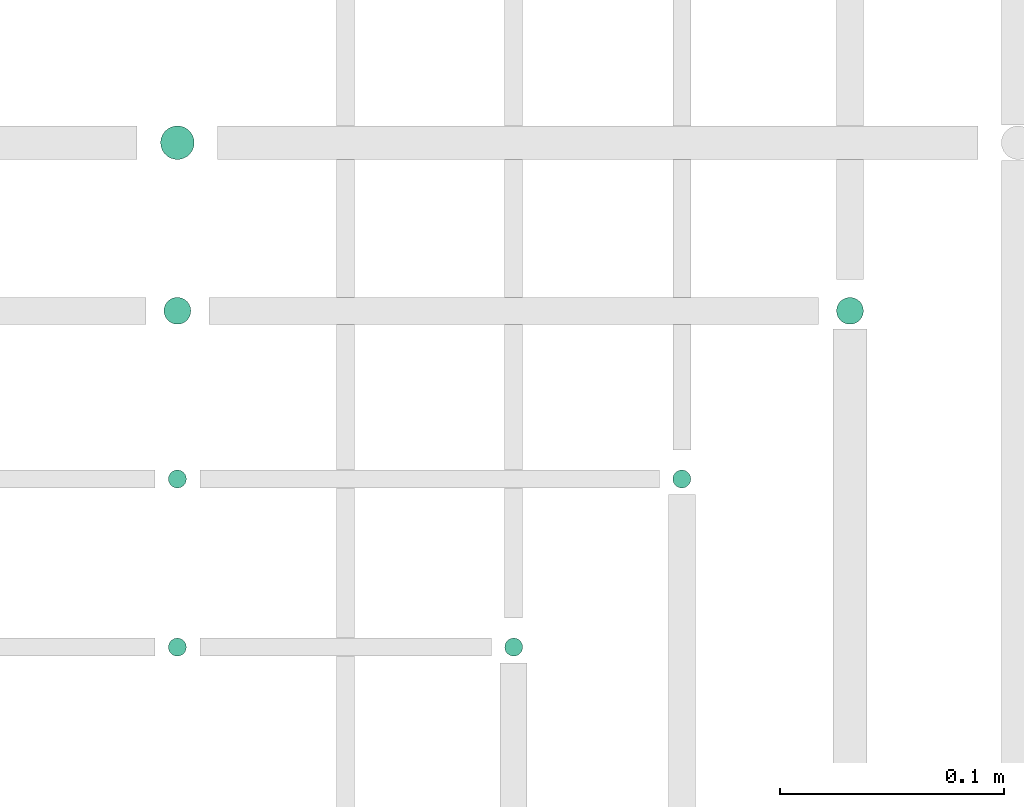
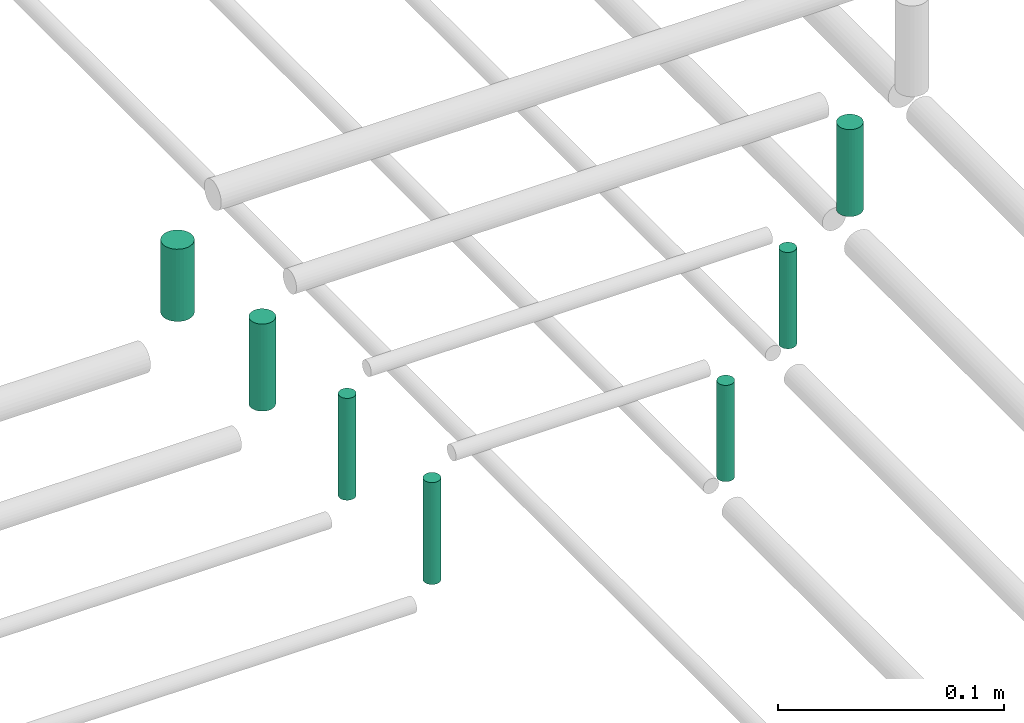
# One storey, part 319 of 331: 7 flow segments.
"""IFC2X3 building model written with IfcOpenShell, lengths in millimetres."""

from ifc_helpers import new_model, entity, si_unit, converted_unit, derived_unit, direction, frame, origin, origin_2d_with_axis, place, context, subcontext, project, spatial, circle, extrude, type_object, element, save


model = new_model("IFC2X3")

# Units and contexts
model_context = context("Model", 3, precision=0.01, world=origin(), true_north=direction((6.12303176911189e-17, 1.0)))
body_context = subcontext(model_context, "Body", "Model", "MODEL_VIEW")
ifc_project = project(units=[si_unit("LENGTHUNIT", "METRE", prefix="MILLI"), si_unit("AREAUNIT", "SQUARE_METRE"), si_unit("VOLUMEUNIT", "CUBIC_METRE"), converted_unit("PLANEANGLEUNIT", "DEGREE", entity("IfcRatioMeasure", 0.0174532925199433), si_unit("PLANEANGLEUNIT", "RADIAN"), dimensions=[0, 0, 0, 0, 0, 0, 0]), si_unit("MASSUNIT", "GRAM", prefix="KILO"), derived_unit("MASSDENSITYUNIT", [(si_unit("MASSUNIT", "GRAM", prefix="KILO"), 1), (si_unit("LENGTHUNIT", "METRE"), -3)]), derived_unit("MOMENTOFINERTIAUNIT", [(si_unit("LENGTHUNIT", "METRE"), 4)]), si_unit("TIMEUNIT", "SECOND"), si_unit("FREQUENCYUNIT", "HERTZ"), si_unit("THERMODYNAMICTEMPERATUREUNIT", "DEGREE_CELSIUS"), derived_unit("THERMALTRANSMITTANCEUNIT", [(si_unit("MASSUNIT", "GRAM", prefix="KILO"), 1), (si_unit("THERMODYNAMICTEMPERATUREUNIT", "KELVIN"), -1), (si_unit("TIMEUNIT", "SECOND"), -3)]), derived_unit("VOLUMETRICFLOWRATEUNIT", [(si_unit("LENGTHUNIT", "METRE"), 3), (si_unit("TIMEUNIT", "SECOND"), -1)]), derived_unit("MASSFLOWRATEUNIT", [(si_unit("MASSUNIT", "GRAM", prefix="KILO"), 1), (si_unit("TIMEUNIT", "SECOND"), -1)]), derived_unit("ROTATIONALFREQUENCYUNIT", [(si_unit("TIMEUNIT", "SECOND"), -1)]), si_unit("ELECTRICCURRENTUNIT", "AMPERE"), si_unit("ELECTRICVOLTAGEUNIT", "VOLT"), si_unit("POWERUNIT", "WATT"), si_unit("FORCEUNIT", "NEWTON", prefix="KILO"), si_unit("ILLUMINANCEUNIT", "LUX"), si_unit("LUMINOUSFLUXUNIT", "LUMEN"), si_unit("LUMINOUSINTENSITYUNIT", "CANDELA"), derived_unit("USERDEFINED", [(si_unit("MASSUNIT", "GRAM", prefix="KILO"), -1), (si_unit("LENGTHUNIT", "METRE"), -2), (si_unit("TIMEUNIT", "SECOND"), 3), (si_unit("LUMINOUSFLUXUNIT", "LUMEN"), 1)]), derived_unit("LINEARVELOCITYUNIT", [(si_unit("LENGTHUNIT", "METRE"), 1), (si_unit("TIMEUNIT", "SECOND"), -1)]), si_unit("PRESSUREUNIT", "PASCAL"), derived_unit("USERDEFINED", [(si_unit("LENGTHUNIT", "METRE"), -2), (si_unit("MASSUNIT", "GRAM", prefix="KILO"), 1), (si_unit("TIMEUNIT", "SECOND"), -2)]), derived_unit("LINEARFORCEUNIT", [(si_unit("MASSUNIT", "GRAM", prefix="KILO"), 1), (si_unit("LENGTHUNIT", "METRE"), 1), (si_unit("TIMEUNIT", "SECOND"), -2), (si_unit("LENGTHUNIT", "METRE"), -1)]), derived_unit("PLANARFORCEUNIT", [(si_unit("MASSUNIT", "GRAM", prefix="KILO"), 1), (si_unit("LENGTHUNIT", "METRE"), 1), (si_unit("TIMEUNIT", "SECOND"), -2), (si_unit("LENGTHUNIT", "METRE"), -2)])], contexts=[model_context])

# Site, building, storey
site_placement = place(None, frame((0.0, -0.00077364408347762, 0.0)))
site = spatial("IfcSite", under=ifc_project, at=site_placement, CompositionType="ELEMENT")
building_placement = place(site_placement, origin())
building = spatial("IfcBuilding", under=site, at=building_placement, CompositionType="ELEMENT")
storey_placement = place(building_placement, origin())
storey = spatial("IfcBuildingStorey", under=building, at=storey_placement, CompositionType="ELEMENT", Elevation=0.0)

# Flow segments
pipe_segment_type = type_object("IfcPipeSegmentType", PredefinedType="NOTDEFINED")
flow_segment_1_placement = place(storey_placement, frame((58193.0947663297, 19062.1612459849, 19068.0)))
element("IfcFlowSegment", 1, at=flow_segment_1_placement, inside=storey, type_object=pipe_segment_type, context=body_context, shape_type="SweptSolid", body=[
    extrude(circle(Radius=7.5, at=origin_2d_with_axis()), frame((9.09527223591419, 9.09527223591636, 0.0)), (0.0, 0.0, 1.0), 39.0000000000085),
])
flow_segment_2_placement = place(building_placement, frame((58494.5947663297, 18988.661245985, 19064.0)))
element("IfcFlowSegment", 2, at=flow_segment_2_placement, inside=storey, type_object=pipe_segment_type, context=body_context, shape_type="SweptSolid", body=[
    extrude(circle(Radius=6.0, at=origin_2d_with_axis()), frame((7.59527223591454, 7.5952722359167, 0.0), z_axis=(0.0, 0.0, 1.0), x_axis=(-1.0, 0.0, 0.0)), (0.0, 0.0, 1.0), 47.0000000000001),
])
flow_segment_3_placement = place(building_placement, frame((58194.5947663297, 18988.661245985, 19064.0)))
element("IfcFlowSegment", 3, at=flow_segment_3_placement, inside=storey, type_object=pipe_segment_type, context=body_context, shape_type="SweptSolid", body=[
    extrude(circle(Radius=6.0, at=origin_2d_with_axis()), frame((7.59527223591454, 7.5952722359167, 0.0)), (0.0, 0.0, 1.0), 47.0000000000131),
])
flow_segment_4_placement = place(building_placement, frame((58421.5947663297, 18915.661245985, 19063.0)))
element("IfcFlowSegment", 4, at=flow_segment_4_placement, inside=storey, type_object=pipe_segment_type, context=body_context, shape_type="SweptSolid", body=[
    extrude(circle(Radius=4.0, at=origin_2d_with_axis()), frame((5.59527223591499, 5.59527223591499, 0.0), z_axis=(0.0, 0.0, 1.0), x_axis=(-1.0, 0.0, 0.0)), (0.0, 0.0, 1.0), 51.9999999999838),
])
flow_segment_5_placement = place(building_placement, frame((58196.5947663297, 18915.661245985, 19060.0)))
element("IfcFlowSegment", 5, at=flow_segment_5_placement, inside=storey, type_object=pipe_segment_type, context=body_context, shape_type="SweptSolid", body=[
    extrude(circle(Radius=4.0, at=origin_2d_with_axis()), frame((5.59527223591499, 5.59527223591499, 0.0)), (0.0, 0.0, 1.0), 55.0000000000135),
])
flow_segment_6_placement = place(building_placement, frame((58346.5947663297, 18840.6612459849, 19063.0)))
element("IfcFlowSegment", 6, at=flow_segment_6_placement, inside=storey, type_object=pipe_segment_type, context=body_context, shape_type="SweptSolid", body=[
    extrude(circle(Radius=4.0, at=origin_2d_with_axis()), frame((5.59527223591499, 5.59527223591499, 0.0), z_axis=(0.0, 0.0, 1.0), x_axis=(-1.0, 0.0, 0.0)), (0.0, 0.0, 1.0), 51.9999999999882),
])
flow_segment_7_placement = place(building_placement, frame((58196.5947663297, 18840.661245985, 19060.0)))
element("IfcFlowSegment", 7, at=flow_segment_7_placement, inside=storey, type_object=pipe_segment_type, context=body_context, shape_type="SweptSolid", body=[
    extrude(circle(Radius=4.0, at=origin_2d_with_axis()), frame((5.59527223591499, 5.59527223591499, 0.0), z_axis=(0.0, 0.0, 1.0), x_axis=(-1.0, 0.0, 0.0)), (0.0, 0.0, 1.0), 55.0000000000243),
])

save(model, "model.ifc")
